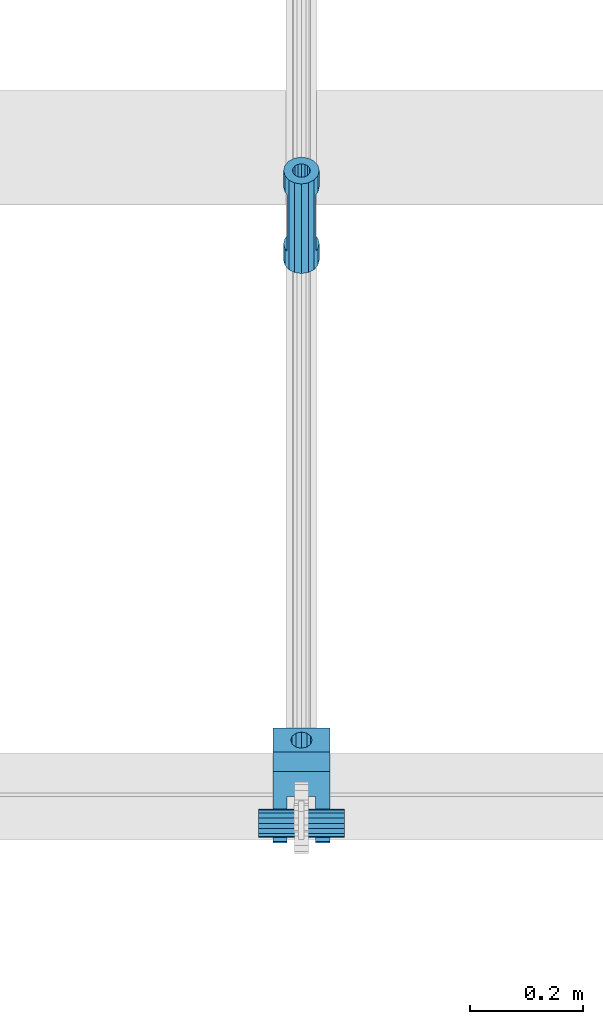
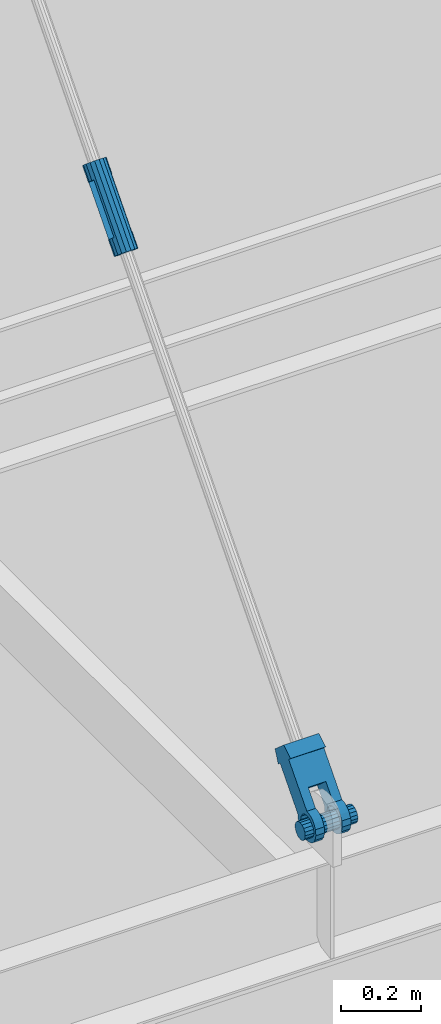
# One storey, part 1204 of 1763: 2 members, 1 beam, 2 elements without a shape of their own.
"""IFC2X3 building model written with IfcOpenShell, lengths in millimetres."""

from ifc_helpers import new_model, si_unit, frame, origin_with_axes, place, context, subcontext, project, spatial, faceted_brep, material, type_object, element, aggregate, save


model = new_model("IFC2X3")

# Units and contexts
model_context = context("Model", 3, precision=1e-05, world=origin_with_axes())
body_context = subcontext(model_context, "Body", "Model", "MODEL_VIEW")
ifc_project = project(units=[si_unit("LENGTHUNIT", "METRE", prefix="MILLI"), si_unit("AREAUNIT", "SQUARE_METRE"), si_unit("VOLUMEUNIT", "CUBIC_METRE"), si_unit("MASSUNIT", "GRAM", prefix="KILO"), si_unit("TIMEUNIT", "SECOND"), si_unit("PLANEANGLEUNIT", "RADIAN"), si_unit("SOLIDANGLEUNIT", "STERADIAN"), si_unit("THERMODYNAMICTEMPERATUREUNIT", "DEGREE_CELSIUS"), si_unit("LUMINOUSINTENSITYUNIT", "LUMEN")], contexts=[model_context])

# Site, building, storey
site_placement = place(None, origin_with_axes())
site = spatial("IfcSite", under=ifc_project, at=site_placement, CompositionType="ELEMENT")
building_placement = place(site_placement, origin_with_axes())
building = spatial("IfcBuilding", under=site, at=building_placement, Name="Undefined", CompositionType="ELEMENT")
storey_placement = place(building_placement, origin_with_axes())
storey = spatial("IfcBuildingStorey", under=building, at=storey_placement, Name="Undefined", CompositionType="ELEMENT", Elevation=0.0)

# Assembly, beam
assembly_1_placement = place(storey_placement, origin_with_axes())
assembly_1 = element("IfcElementAssembly", 1, at=assembly_1_placement, inside=storey, Name="PIN", AssemblyPlace="NOTDEFINED", PredefinedType="RIGID_FRAME")
ifc_material_1 = material()
beam_type = type_object("IfcBeamType", PredefinedType="NOTDEFINED")
beam_placement = place(assembly_1_placement, frame((-52094.8270083207, -16652.8775988321, 8839.20000000015), z_axis=(0.0, 0.0, 1.0), x_axis=(1.0, 0.0, 0.0)))
beam = element("IfcBeam", 2, at=beam_placement, type_object=beam_type, material=ifc_material_1, Name="PIN", context=body_context, shape_type="Brep", body=[
    faceted_brep([(0.0, -25.4000000000015, 0.0), (0.0, -23.466540125788, -9.72015918207308), (152.400103102711, -23.466540125788, -9.72015918207308), (152.400103102711, -25.4000000000015, 0.0), (0.0, -17.9605122421381, -17.9605122421385), (152.400103102711, -17.9605122421381, -17.9605122421385), (0.0, -9.72015918207398, -23.4665401257867), (152.400103102711, -9.72015918207398, -23.4665401257867), (0.0, 0.0, -25.4000000000001), (152.400103102711, 0.0, -25.4000000000001), (0.0, 9.72015918207398, -23.4665401257867), (152.400103102711, 9.72015918207398, -23.4665401257867), (0.0, 17.9605122421381, -17.9605122421385), (152.400103102711, 17.9605122421381, -17.9605122421385), (0.0, 23.466540125788, -9.72015918207308), (152.400103102711, 23.466540125788, -9.72015918207308), (0.0, 25.4000000000015, 0.0), (152.400103102711, 25.4000000000015, 0.0), (0.0, 23.466540125788, 9.72015918207308), (152.400103102711, 23.466540125788, 9.72015918207308), (0.0, 17.9605122421381, 17.9605122421385), (152.400103102711, 17.9605122421381, 17.9605122421385), (0.0, 9.72015918207398, 23.4665401257867), (152.400103102711, 9.72015918207398, 23.4665401257867), (0.0, 0.0, 25.4000000000001), (152.400103102711, 0.0, 25.4000000000001), (0.0, -9.72015918207398, 23.4665401257867), (152.400103102711, -9.72015918207398, 23.4665401257867), (0.0, -17.9605122421381, 17.9605122421385), (152.400103102711, -17.9605122421381, 17.9605122421385), (0.0, -23.466540125788, 9.72015918207308), (152.400103102711, -23.466540125788, 9.72015918207308)], [[[0, 1, 2, 3]], [[1, 4, 5, 2]], [[4, 6, 7, 5]], [[6, 8, 9, 7]], [[8, 10, 11, 9]], [[10, 12, 13, 11]], [[12, 14, 15, 13]], [[14, 16, 17, 15]], [[16, 18, 19, 17]], [[18, 20, 21, 19]], [[20, 22, 23, 21]], [[22, 24, 25, 23]], [[24, 26, 27, 25]], [[26, 28, 29, 27]], [[28, 30, 31, 29]], [[30, 0, 3, 31]], [[5, 7, 9, 11, 13, 15, 17, 19, 21, 23, 25, 27, 29, 31, 3, 2]], [[30, 28, 26, 24, 22, 20, 18, 16, 14, 12, 10, 8, 6, 4, 1, 0]]]),
])
aggregate(assembly_1, [beam])

# Assembly, members
assembly_2_placement = place(storey_placement, origin_with_axes())
assembly_2 = element("IfcElementAssembly", 3, at=assembly_2_placement, inside=storey, Name="HANGER ROD", AssemblyPlace="NOTDEFINED", PredefinedType="RIGID_FRAME")
ifc_material_2 = material(Name="STEEL/A36")
member_type_1 = type_object("IfcMemberType", PredefinedType="NOTDEFINED")
member_1_placement = place(assembly_2_placement, frame((-52018.627008321, -15652.3502159622, 9969.26476185088), z_axis=(1.0, 0.0, 0.0), x_axis=(0.0, 0.659331589097062, 0.75185228311068)))
member_1 = element("IfcMember", 4, at=member_1_placement, type_object=member_type_1, material=ifc_material_2, context=body_context, shape_type="Brep", body=[
    faceted_brep([(44.4499999991772, 0.0, 31.75), (44.4499999991772, -12.1501989775898, 29.3331751572332), (44.4499999991799, -17.4625000019951, 25.7836090945275), (44.4499999991799, -17.4625000019951, -25.7836090945275), (44.4499999991772, -12.1501989775898, -29.3331751572332), (44.4499999991772, 0.0, -31.75), (44.4499999991772, 12.1501989775898, -29.3331751572332), (44.4499999991763, 17.4624999979787, -25.7836090972123), (44.4499999991763, 17.4624999979787, 25.7836090972123), (44.4499999991754, 12.1501989775898, 29.3331751572332), (44.4499999991772, 0.0, 15.875), (44.4499999991781, 6.07509948879306, 14.6665875786202), (44.4499999991754, 11.225320151334, 11.2253201513377), (44.4499999991754, 14.666587578613, 6.07509948879306), (44.4499999991754, 15.8749999999964, 0.0), (44.4499999991754, 14.666587578613, -6.07509948879306), (44.4499999991754, 11.225320151334, -11.2253201513377), (44.4499999991781, 6.07509948879306, -14.6665875786202), (44.4499999991772, 0.0, -15.875), (44.4499999991781, -6.07509948879306, -14.6665875786202), (44.449999999179, -11.225320151334, -11.2253201513377), (44.449999999179, -14.666587578613, -6.07509948879306), (44.449999999179, -15.8749999999964, 0.0), (44.449999999179, -14.666587578613, 6.07509948879306), (44.449999999179, -11.225320151334, 11.2253201513377), (44.4499999991781, -6.07509948879306, 14.6665875786202), (196.849999998747, 17.4624999979933, -25.7836090972123), (196.849999998747, 17.4624999979933, 25.7836090972123), (196.849999998745, 1.45519152283669e-11, 31.75), (196.849999998745, 12.1501989776043, 29.3331751572332), (196.849999998745, 12.1501989776043, -29.3331751572332), (196.849999998745, 1.45519152283669e-11, -31.75), (196.849999998748, -12.1501989775752, -29.3331751572332), (196.849999998748, -17.4625000019805, -25.7836090945275), (196.849999998748, -17.4625000019805, 25.7836090945275), (196.849999998748, -12.1501989775752, 29.3331751572332), (196.849999998745, 1.45519152283669e-11, 15.875), (196.849999998748, -6.07509948877851, 14.6665875786202), (196.849999998748, -11.2253201513195, 11.2253201513377), (196.849999998748, -14.666587578602, 6.07509948879306), (196.849999998748, -15.8749999999818, 0.0), (196.849999998748, -14.666587578602, -6.07509948879306), (196.849999998748, -11.2253201513195, -11.2253201513377), (196.849999998748, -6.07509948877851, -14.6665875786202), (196.849999998745, 1.45519152283669e-11, -15.875), (196.849999998746, 6.07509948880761, -14.6665875786202), (196.849999998747, 11.2253201513486, -11.2253201513377), (196.849999998745, 14.6665875786275, -6.07509948879306), (196.849999998745, 15.8750000000109, 0.0), (196.849999998745, 14.6665875786275, 6.07509948879306), (196.849999998747, 11.2253201513486, 11.2253201513377), (196.849999998746, 6.07509948880761, 14.6665875786202), (241.299999999548, -12.1501989775679, 29.3331751572332), (241.299999999548, 1.81898940354586e-11, 31.75), (241.299999999546, 12.1501989776079, -29.3331751572332), (241.299999999548, 1.81898940354586e-11, -31.75), (241.299999999548, -12.1501989775679, -29.3331751572332), (-1.36424205265939e-12, -29.3331751572296, -12.1501989775934), (-1.36424205265939e-12, -22.4506403026717, -22.4506403026753), (241.29999999955, -22.4506403026498, -22.4506403026753), (241.29999999955, -29.3331751572077, -12.1501989775934), (0.0, 0.0, -31.75), (-4.09272615797818e-12, 12.1501989775825, -29.3331751572332), (-2.27373675443232e-12, -12.1501989775934, -29.3331751572332), (-3.18323145620525e-12, 22.4506403026644, -22.4506403026753), (241.299999999546, 22.4506403026862, -22.4506403026753), (-5.00222085975111e-12, 29.3331751572223, -12.1501989775934), (241.299999999543, 29.3331751572441, -12.1501989775934), (-5.91171556152403e-12, 31.7499999999891, 0.0), (241.299999999542, 31.7500000000109, 0.0), (-5.00222085975111e-12, 29.3331751572223, 12.1501989775934), (241.299999999543, 29.3331751572441, 12.1501989775934), (-3.18323145620525e-12, 22.4506403026644, 22.4506403026753), (241.299999999546, 22.4506403026862, 22.4506403026753), (0.0, 0.0, 31.75), (-2.27373675443232e-12, -12.1501989775934, 29.3331751572332), (-4.09272615797818e-12, 12.1501989775825, 29.3331751572332), (241.299999999546, 12.1501989776079, 29.3331751572332), (-1.36424205265939e-12, -22.4506403026717, 22.4506403026753), (241.29999999955, -22.4506403026498, 22.4506403026753), (-1.36424205265939e-12, -29.3331751572296, 12.1501989775934), (241.29999999955, -29.3331751572077, 12.1501989775934), (-4.54747350886464e-13, -31.7499999999964, 0.0), (241.29999999955, -31.7499999999745, 0.0), (241.29999999955, -15.8749999999782, 0.0), (241.299999999549, -14.6665875785948, -6.07509948879306), (241.299999999549, -11.2253201513158, -11.2253201513377), (241.299999999547, -6.07509948877487, -14.6665875786202), (241.299999999548, 1.81898940354586e-11, -15.875), (241.299999999547, 6.07509948881125, -14.6665875786202), (241.299999999546, 11.2253201513558, -11.2253201513377), (241.299999999548, 14.6665875786312, -6.07509948879306), (241.299999999546, 15.8750000000146, 0.0), (241.299999999548, 14.6665875786312, 6.07509948879306), (241.299999999546, 11.2253201513558, 11.2253201513377), (241.299999999547, 6.07509948881125, 14.6665875786202), (241.299999999548, 1.81898940354586e-11, 15.875), (241.299999999549, -11.2253201513158, 11.2253201513377), (241.299999999549, -14.6665875785948, 6.07509948879306), (241.299999999547, -6.07509948877487, 14.6665875786202), (-1.36424205265939e-12, -14.6665875786166, -6.07509948879306), (-1.36424205265939e-12, -11.2253201513377, -11.2253201513377), (-2.27373675443232e-12, -6.07509948880033, -14.6665875786202), (4.91792532185561e-12, 0.0, -15.875), (-4.09272615797818e-12, 6.07509948878942, -14.6665875786202), (-4.09272615797818e-12, 11.2253201513304, -11.2253201513377), (-2.27373675443232e-12, 14.6665875786093, -6.07509948879306), (0.0, 15.875, 0.0), (-2.27373675443232e-12, 14.6665875786093, 6.07509948879306), (-4.09272615797818e-12, 11.2253201513304, 11.2253201513377), (-3.18323145620525e-12, 6.07509948878942, 14.6665875786202), (-1.64518337079051e-12, 0.0, 15.875), (-2.27373675443232e-12, -6.07509948880033, 14.6665875786202), (-1.36424205265939e-12, -11.2253201513377, 11.2253201513377), (-1.36424205265939e-12, -14.6665875786166, 6.07509948879306), (0.0, -15.875, 0.0)], [[[0, 1, 2, 3, 4, 5, 6, 7, 8, 9], [10, 11, 12, 13, 14, 15, 16, 17, 18, 19, 20, 21, 22, 23, 24, 25]], [[8, 7, 26, 27]], [[28, 29, 27, 26, 30, 31, 32, 33, 34, 35], [36, 37, 38, 39, 40, 41, 42, 43, 44, 45, 46, 47, 48, 49, 50, 51]], [[34, 33, 3, 2]], [[52, 53, 28, 35]], [[54, 55, 31, 30]], [[55, 56, 32, 31]], [[57, 58, 59, 60]], [[61, 62, 6, 5]], [[63, 61, 5, 4]], [[56, 59, 58, 63, 4, 3, 33, 32]], [[6, 62, 64, 65, 54, 30, 26, 7]], [[64, 66, 67, 65]], [[66, 68, 69, 67]], [[68, 70, 71, 69]], [[70, 72, 73, 71]], [[74, 75, 1, 0]], [[76, 74, 0, 9]], [[77, 73, 72, 76, 9, 8, 27, 29]], [[53, 77, 29, 28]], [[2, 1, 75, 78, 79, 52, 35, 34]], [[78, 80, 81, 79]], [[80, 82, 83, 81]], [[84, 85, 41, 40]], [[85, 86, 42, 41]], [[86, 87, 43, 42]], [[87, 88, 44, 43]], [[88, 89, 45, 44]], [[89, 90, 46, 45]], [[90, 91, 47, 46]], [[91, 92, 48, 47]], [[92, 93, 49, 48]], [[93, 94, 50, 49]], [[94, 95, 51, 50]], [[95, 96, 36, 51]], [[97, 98, 39, 38]], [[99, 97, 38, 37]], [[96, 99, 37, 36]], [[98, 84, 40, 39]], [[59, 56, 55, 54, 65, 67, 69, 71, 73, 77, 53, 52, 79, 81, 83, 60], [97, 99, 96, 95, 94, 93, 92, 91, 90, 89, 88, 87, 86, 85, 84, 98]], [[82, 57, 60, 83]], [[80, 78, 75, 74, 76, 72, 70, 68, 66, 64, 62, 61, 63, 58, 57, 82], [100, 101, 102, 103, 104, 105, 106, 107, 108, 109, 110, 111, 112, 113, 114, 115]], [[112, 111, 10, 25]], [[113, 112, 25, 24]], [[114, 113, 24, 23]], [[115, 114, 23, 22]], [[100, 115, 22, 21]], [[101, 100, 21, 20]], [[102, 101, 20, 19]], [[103, 102, 19, 18]], [[104, 103, 18, 17]], [[105, 104, 17, 16]], [[106, 105, 16, 15]], [[107, 106, 15, 14]], [[108, 107, 14, 13]], [[109, 108, 13, 12]], [[110, 109, 12, 11]], [[111, 110, 11, 10]]]),
])
member_type_2 = type_object("IfcMemberType", PredefinedType="NOTDEFINED")
member_2_placement = place(assembly_2_placement, frame((-52018.627008321, -16672.6598761127, 8805.7801660124), z_axis=(-1.0, 0.0, 0.0), x_axis=(0.0, 0.659331589097062, 0.75185228311068)))
member_2 = element("IfcMember", 5, at=member_2_placement, type_object=member_type_2, material=ifc_material_2, context=body_context, shape_type="Brep", body=[
    faceted_brep([(254.000002114522, 9.52500000169675, 16.4977839419953), (134.273330688089, 9.52500000160944, 16.4977839419953), (134.273330688083, 16.4977839436942, 9.52499999989959), (254.000002182145, 16.4977839437852, 9.52499999989959), (134.273330688081, 19.0500000015963, -1.01863406598568e-10), (254.000002023278, 19.0500000016909, -1.01863406598568e-10), (134.273330688083, 16.4977839436942, -9.52500000010332), (254.000001680489, 16.4977839437852, -9.52500000010332), (134.273330688089, 9.52500000160944, -16.497783942199), (254.000001245629, 9.52500000169675, -16.497783942199), (134.273330688098, 1.61890056915581e-09, -19.0500000001048), (254.000000835218, 1.70985003933311e-09, -19.0500000001048), (134.273330688103, -9.52499999837164, -16.497783942199), (254.000000559224, -9.52499999827705, -16.497783942199), (134.273330688109, -16.4977839404564, -9.52500000010332), (254.000000491603, -16.4977839403655, -9.52500000010332), (134.273330688112, -19.0499999983585, -1.01863406598568e-10), (254.000000650468, -19.0499999982676, -1.01863406598568e-10), (134.273330688109, -16.4977839404564, 9.52499999989959), (254.000000993259, -16.4977839403655, 9.52499999989959), (134.273330688103, -9.52499999837164, 16.4977839419953), (254.000001428119, -9.52499999827705, 16.4977839419953), (134.273330688098, 1.61890056915581e-09, 19.049999999901), (254.00000183853, 1.70985003933311e-09, 19.049999999901), (253.999999999431, 28.5749978801541, -50.8000000000029), (254.000000624264, 28.5749978801541, 50.8000000000029), (254.000004725771, -28.5826898869382, 50.8000000000029), (253.999999999356, -28.5826898869382, -50.8000000000029), (215.899998547231, 41.2749984764123, -50.8000000000029), (215.899998547231, 41.2749984764123, 50.8000000000029), (215.900005813682, 28.5749978523527, -50.8000000000029), (215.900005813682, 28.5749978523527, 50.8000000000029), (71.5070499061785, -35.274116161534, -50.8000000000029), (78.4980859437883, -28.5827170649136, -50.8000000000029), (78.4980859437883, -28.5827170649136, -25.3999992370664), (71.5070499061785, -35.274116161534, -25.3999992370664), (63.2335594872948, -40.2939531148404, -50.8000000000029), (63.2335594872948, -40.2939531148404, -25.3999992370664), (54.0697628809667, -43.4042969072325, -50.8000000000029), (54.0697628809667, -43.4042969072325, -25.3999992370664), (44.4500007625898, -44.4499999999498, -50.8000000000029), (44.4500007625898, -44.4500001906781, -25.3999992370664), (27.4397222623497, -41.066445304652, -50.8000000000029), (27.4397222623497, -41.066445304652, -25.3999992370664), (13.0191044786457, -31.4308962839314, -50.8000000000029), (13.0191044786457, -31.4308962839314, -25.3999992370664), (3.38355545789955, -17.0102785002382, -50.8000000000029), (3.38355545789955, -17.0102785002382, -25.3999992370664), (0.0, 0.0, -50.7999992370605), (0.0, 0.0, -25.4000000000001), (3.38355373177319, 17.0102772902901, -50.8000000000029), (3.38355373177319, 17.0102772902901, -25.3999992370664), (13.0191026972475, 31.4308957019275, -50.8000000000029), (13.0191026972475, 31.4308957019275, -25.3999992370664), (27.4397209215654, 41.0664449477481, -50.8000000000029), (27.4397209215654, 41.0664449477481, -25.3999992370664), (44.4500000032872, 44.4500000000189, -50.8000000000029), (44.4500000032872, 44.4500000003973, -25.3999992370664), (54.0697566428225, 43.3965760804131, -50.8000000000029), (54.0697566428225, 43.3965760804131, -25.3999992370664), (63.2335536975006, 40.2862336089929, -50.8000000000029), (63.2335536975006, 40.2862336089929, -25.3999992370664), (71.507044839982, 35.2663978483215, -50.8000000000029), (71.507044839982, 35.2663978483215, -25.3999992370664), (78.49808184214, 28.5749997594721, -50.8000000000029), (78.49808184214, 28.5749997594721, -25.3999992370664), (78.49808184214, 28.5749997594721, 50.8000000000029), (134.273330688678, 28.5749989853175, -25.3999992370664), (134.273330688678, 28.5749989853175, 25.3999999999942), (78.49808184214, 28.5749997594721, 25.3999999999942), (71.507044839982, 35.2663978483215, 50.8000000000029), (71.507044839982, 35.2663978483215, 25.3999999999942), (63.2335536975006, 40.2862336089929, 50.8000000000029), (63.2335536975006, 40.2862336089929, 25.3999999999942), (54.0697566428225, 43.3965760804131, 50.8000000000029), (54.0697566428225, 43.3965760804131, 25.3999999999942), (44.4500000032872, 44.4500000015396, 50.8000000000029), (44.450000003289, 44.4500000011612, 25.3999999999942), (27.4397209215654, 41.0664449477481, 50.8000000000029), (27.4397209215654, 41.0664449477481, 25.3999999999942), (13.0191026972475, 31.4308957019275, 50.8000000000029), (13.0191026972475, 31.4308957019275, 25.3999999999942), (3.38355373177319, 17.0102772902901, 50.8000000000029), (3.38355373177319, 17.0102772902901, 25.3999999999942), (0.0, 0.0, 50.7999992370605), (0.0, 0.0, 25.4000000000001), (3.38355545789955, -17.0102785002382, 50.8000000000029), (3.38355545789955, -17.0102785002382, 25.3999999999942), (13.0191044786457, -31.4308962839314, 50.8000000000029), (13.0191044786457, -31.4308962839314, 25.3999999999942), (27.4397222623497, -41.066445304652, 50.8000000000029), (27.4397222623497, -41.066445304652, 25.3999999999942), (44.4500007625898, -44.4500007628594, 50.8000000000029), (44.4500007625898, -44.4500005721347, 25.3999999999942), (54.0697628809667, -43.4042969072325, 50.8000000000029), (54.0697628809667, -43.4042969072325, 25.3999999999942), (63.2335594872948, -40.2939531148404, 50.8000000000029), (63.2335594872948, -40.2939531148404, 25.3999999999942), (71.5070499061785, -35.274116161534, 50.8000000000029), (71.5070499061785, -35.274116161534, 25.3999999999942), (78.4980859437883, -28.5827170649136, 50.8000000000029), (78.4980859437883, -28.5827170649136, 25.3999999999942), (215.900009915221, -28.5826953512624, 50.8000000000029), (215.900004479429, -41.2826959753438, 50.8000000000029), (68.3213099888762, -20.9337779588823, 50.8000000000029), (58.493204713217, -28.4754438363161, 50.8000000000029), (46.5271488219641, -31.681981520971, 50.8000000000029), (34.2448658519861, -30.0652247177059, 50.8000000000029), (23.5162220462953, -23.8713099938795, 50.8000000000029), (15.9745561689124, -14.0432047182112, 50.8000000000029), (12.7680184842902, -2.07714882693108, 50.8000000000029), (14.3847752875827, 10.2051341430815, 50.8000000000029), (20.5786900114208, 20.933777948816, 50.8000000000029), (30.4067952870791, 28.4754438262462, 50.8000000000029), (42.3728511783329, 31.6819815109047, 50.8000000000029), (54.65513414831, 30.0652247076396, 50.8000000000029), (65.3837779539981, 23.8713099838096, 50.8000000000029), (72.9254438313847, 14.0432047081449, 50.8000000000029), (76.1319815160032, 2.07714881686115, 50.8000000000029), (74.5152247127153, -10.2051341531514, 50.8000000000029), (68.3213099888762, -20.9337779588823, 25.3999999999942), (58.493204713217, -28.4754438363161, 25.3999999999942), (46.5271488219641, -31.681981520971, 25.3999999999942), (34.2448658519861, -30.0652247177059, 25.3999999999942), (23.5162220462953, -23.8713099938795, 25.3999999999942), (15.9745561689124, -14.0432047182112, 25.3999999999942), (12.7680184842902, -2.07714882693108, 25.3999999999942), (14.3847752875827, 10.2051341430815, 25.3999999999942), (20.5786900114208, 20.933777948816, 25.3999999999942), (30.4067952870791, 28.4754438262462, 25.3999999999942), (42.3728511783329, 31.6819815109047, 25.3999999999942), (54.65513414831, 30.0652247076396, 25.3999999999942), (65.3837779539981, 23.8713099838096, 25.3999999999942), (72.9254438313847, 14.0432047081449, 25.3999999999942), (76.1319815160032, 2.07714881686115, 25.3999999999942), (74.5152247127153, -10.2051341531514, 25.3999999999942), (134.273330688533, -28.5827082507421, 25.3999999999942), (215.900009915221, -28.5826953512624, -50.8000000000029), (134.273330688533, -28.5827082507421, -25.3999992370664), (215.900004479429, -41.2826959753438, -50.8000000000029), (65.3837779539981, 23.8713099838096, -50.8000000000029), (54.65513414831, 30.0652247076396, -50.8000000000029), (42.3728511783329, 31.6819815109047, -50.8000000000029), (30.4067952870791, 28.4754438262462, -50.8000000000029), (20.5786900114208, 20.933777948816, -50.8000000000029), (14.3847752875827, 10.2051341430815, -50.8000000000029), (12.7680184842902, -2.07714882693108, -50.8000000000029), (15.9745561689124, -14.0432047182112, -50.8000000000029), (23.5162220462953, -23.8713099938795, -50.8000000000029), (34.2448658519861, -30.0652247177059, -50.8000000000029), (46.5271488219641, -31.681981520971, -50.8000000000029), (58.493204713217, -28.4754438363161, -50.8000000000029), (68.3213099888762, -20.9337779588823, -50.8000000000029), (74.5152247127153, -10.2051341531514, -50.8000000000029), (76.1319815160032, 2.07714881686115, -50.8000000000029), (72.9254438313847, 14.0432047081449, -50.8000000000029), (65.3837779539981, 23.8713099838096, -25.3999992370664), (54.65513414831, 30.0652247076396, -25.3999992370664), (42.3728511783329, 31.6819815109047, -25.3999992370664), (30.4067952870791, 28.4754438262462, -25.3999992370664), (20.5786900114208, 20.933777948816, -25.3999992370664), (14.3847752875827, 10.2051341430815, -25.3999992370664), (12.7680184842902, -2.07714882693108, -25.3999992370664), (15.9745561689124, -14.0432047182112, -25.3999992370664), (23.5162220462953, -23.8713099938795, -25.3999992370664), (34.2448658519861, -30.0652247177059, -25.3999992370664), (46.5271488219641, -31.681981520971, -25.3999992370664), (58.493204713217, -28.4754438363161, -25.3999992370664), (68.3213099888762, -20.9337779588823, -25.3999992370664), (74.5152247127153, -10.2051341531514, -25.3999992370664), (76.1319815160032, 2.07714881686115, -25.3999992370664), (72.9254438313847, 14.0432047081449, -25.3999992370664)], [[[0, 1, 2, 3]], [[3, 2, 4, 5]], [[5, 4, 6, 7]], [[7, 6, 8, 9]], [[9, 8, 10, 11]], [[11, 10, 12, 13]], [[13, 12, 14, 15]], [[15, 14, 16, 17]], [[17, 16, 18, 19]], [[19, 18, 20, 21]], [[21, 20, 22, 23]], [[23, 22, 1, 0]], [[24, 25, 26, 27], [3, 5, 7, 9, 11, 13, 15, 17, 19, 21, 23, 0]], [[25, 24, 28, 29]], [[29, 28, 30, 31]], [[32, 33, 34, 35]], [[36, 32, 35, 37]], [[38, 36, 37, 39]], [[40, 38, 39, 41]], [[42, 40, 41, 43]], [[44, 42, 43, 45]], [[46, 44, 45, 47]], [[48, 46, 47, 49]], [[50, 48, 49, 51]], [[52, 50, 51, 53]], [[54, 52, 53, 55]], [[56, 54, 55, 57]], [[58, 56, 57, 59]], [[60, 58, 59, 61]], [[62, 60, 61, 63]], [[64, 62, 63, 65]], [[66, 31, 30, 64, 65, 67, 68, 69]], [[70, 66, 69, 71]], [[72, 70, 71, 73]], [[74, 72, 73, 75]], [[76, 74, 75, 77]], [[78, 76, 77, 79]], [[80, 78, 79, 81]], [[82, 80, 81, 83]], [[84, 82, 83, 85]], [[86, 84, 85, 87]], [[88, 86, 87, 89]], [[90, 88, 89, 91]], [[92, 90, 91, 93]], [[94, 92, 93, 95]], [[96, 94, 95, 97]], [[98, 96, 97, 99]], [[100, 98, 99, 101]], [[25, 29, 31, 66, 70, 72, 74, 76, 78, 80, 82, 84, 86, 88, 90, 92, 94, 96, 98, 100, 102, 103, 26], [104, 105, 106, 107, 108, 109, 110, 111, 112, 113, 114, 115, 116, 117, 118, 119]], [[105, 104, 120, 121]], [[106, 105, 121, 122]], [[107, 106, 122, 123]], [[108, 107, 123, 124]], [[109, 108, 124, 125]], [[110, 109, 125, 126]], [[111, 110, 126, 127]], [[112, 111, 127, 128]], [[113, 112, 128, 129]], [[114, 113, 129, 130]], [[115, 114, 130, 131]], [[116, 115, 131, 132]], [[117, 116, 132, 133]], [[118, 117, 133, 134]], [[119, 118, 134, 135]], [[104, 119, 135, 120]], [[101, 99, 97, 95, 93, 91, 89, 87, 85, 83, 81, 79, 77, 75, 73, 71, 69, 68, 136], [134, 133, 132, 131, 130, 129, 128, 127, 126, 125, 124, 123, 122, 121, 120, 135]], [[34, 33, 137, 102, 100, 101, 136, 138]], [[102, 137, 139, 103]], [[26, 103, 139, 27]], [[137, 33, 32, 36, 38, 40, 42, 44, 46, 48, 50, 52, 54, 56, 58, 60, 62, 64, 30, 28, 24, 27, 139], [140, 141, 142, 143, 144, 145, 146, 147, 148, 149, 150, 151, 152, 153, 154, 155]], [[141, 140, 156, 157]], [[142, 141, 157, 158]], [[143, 142, 158, 159]], [[144, 143, 159, 160]], [[145, 144, 160, 161]], [[146, 145, 161, 162]], [[147, 146, 162, 163]], [[148, 147, 163, 164]], [[149, 148, 164, 165]], [[150, 149, 165, 166]], [[151, 150, 166, 167]], [[152, 151, 167, 168]], [[153, 152, 168, 169]], [[154, 153, 169, 170]], [[155, 154, 170, 171]], [[140, 155, 171, 156]], [[138, 67, 65, 63, 61, 59, 57, 55, 53, 51, 49, 47, 45, 43, 41, 39, 37, 35, 34], [170, 169, 168, 167, 166, 165, 164, 163, 162, 161, 160, 159, 158, 157, 156, 171]], [[136, 68, 67, 138], [18, 16, 14, 12, 10, 8, 6, 4, 2, 1, 22, 20]]]),
])
aggregate(assembly_2, [member_1, member_2])

save(model, "model.ifc")
